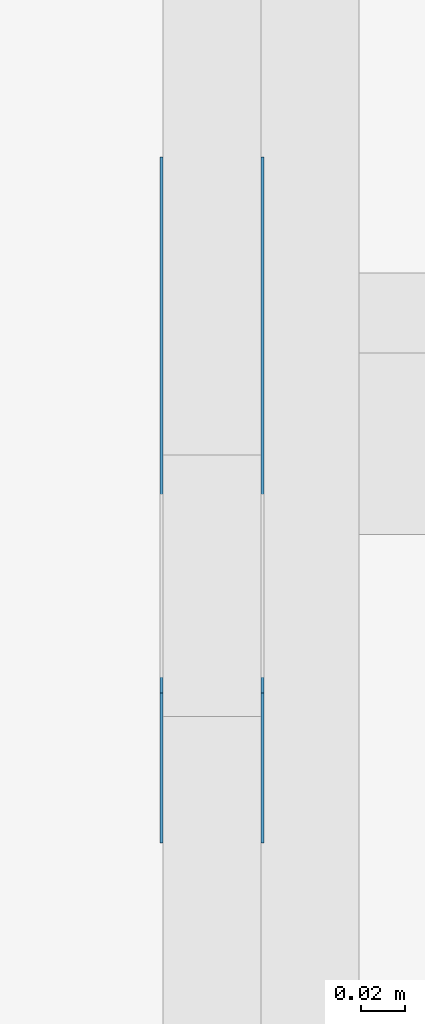
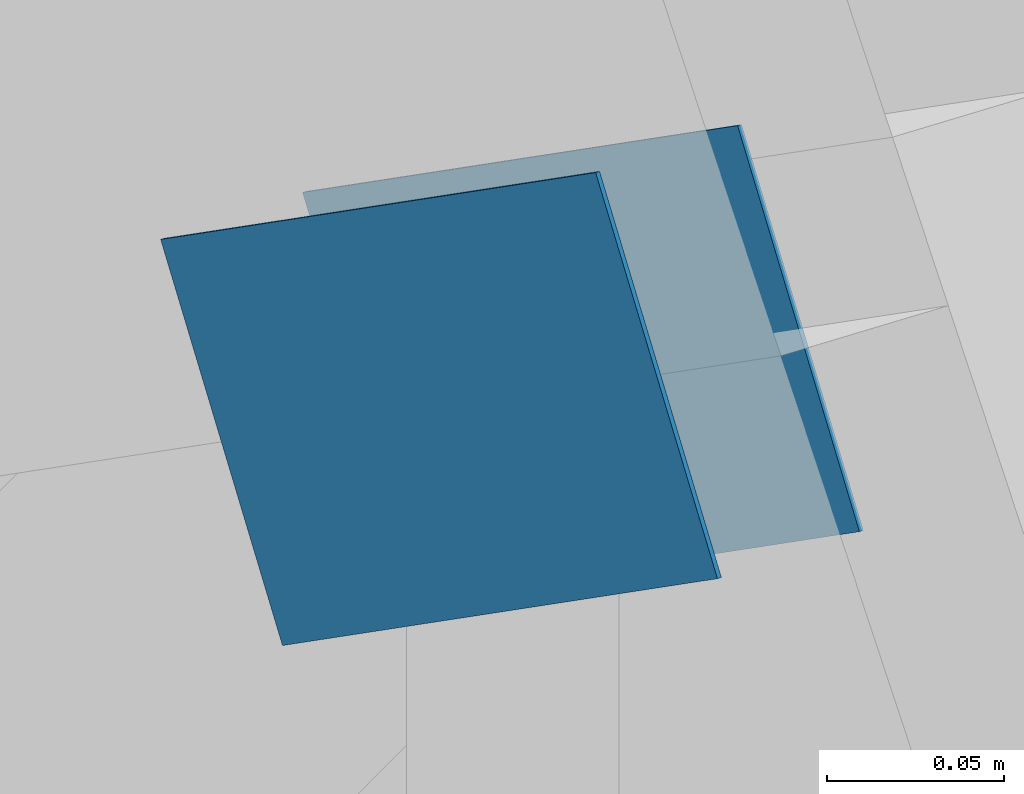
# One storey, part 59 of 70: 2 plates, 1 element without a shape of its own.
"""IFC2X3 building model written with IfcOpenShell, lengths in millimetres."""

from ifc_helpers import new_model, si_unit, frame, origin, origin_with_axes, origin_2d, place, context, project, spatial, faceted_brep, element, aggregate, save


model = new_model("IFC2X3")

# Units and contexts
model_context = context("Model", 3, precision=1e-05, world=origin())
plan_context = context("Plan", 2, precision=1e-05, world=origin_2d())
ifc_project = project(units=[si_unit("LENGTHUNIT", "METRE", prefix="MILLI"), si_unit("AREAUNIT", "SQUARE_METRE"), si_unit("VOLUMEUNIT", "CUBIC_METRE"), si_unit("SOLIDANGLEUNIT", "STERADIAN"), si_unit("PLANEANGLEUNIT", "RADIAN"), si_unit("MASSUNIT", "GRAM"), si_unit("TIMEUNIT", "SECOND"), si_unit("THERMODYNAMICTEMPERATUREUNIT", "DEGREE_CELSIUS"), si_unit("LUMINOUSINTENSITYUNIT", "LUMEN")], contexts=[model_context, plan_context])

# Site, building, storey
site_placement = place(None, origin_with_axes())
site = spatial("IfcSite", under=ifc_project, at=site_placement, CompositionType="ELEMENT")
building_placement = place(site_placement, origin_with_axes())
building = spatial("IfcBuilding", under=site, at=building_placement, Name="Layout 1", CompositionType="ELEMENT")
storey_placement = place(building_placement, origin_with_axes())
storey = spatial("IfcBuildingStorey", under=building, at=storey_placement, Name="Storey 1", CompositionType="ELEMENT", Elevation=0.0)

# Assembly, plates
assembly_placement = place(storey_placement, frame((11150.0, 8000.0, -9.081170196248781e-13), z_axis=(-1.0, 1.836909530733566e-16, 6.123031769111886e-17), x_axis=(-1.836909530733566e-16, -1.0, 0.0)))
assembly = element("IfcElementAssembly", 1, at=assembly_placement, inside=storey, Name="T3", AssemblyPlace="FACTORY", PredefinedType="TRUSS")
plate_1_placement = place(assembly_placement, frame((1312.2224814137073, 1607.5305531611004, 0.0), z_axis=(0.0, 0.0, 1.0), x_axis=(0.8191520442886487, 0.5735764363515361, 0.0)))
plate_1 = element("IfcPlate", 2, at=plate_1_placement, context=model_context, shape_type="Brep", body=[
    faceted_brep([(300.00000000000045, 120.0, 1.3), (0.0, 120.0, 1.3), (4.547473508864641e-13, 0.0, 1.3), (300.00000000000045, 0.0, 1.3), (0.0, 120.0, 0.0), (300.00000000000045, 120.0, 3.6738190614671375e-14), (300.00000000000045, 1.1368683772161603e-13, 3.6738190614671375e-14), (4.547473508864641e-13, 1.1368683772161603e-13, 5.56886495279458e-29), (300.00000000000045, -5.510728592200723e-14, 1.0335317815093051e-29), (300.00000000000045, -5.5027686509008776e-14, 1.3), (4.547473508864641e-13, 7.959941299819867e-17, 1.3), (4.547473508864641e-13, -2.558622685737995e-28, 1.566652798994412e-44), (300.00000000000045, 120.00000000000011, 0.0), (300.00000000000045, 120.00000000000011, 1.3), (300.00000000000045, 1.1368683772161603e-13, 1.3), (300.00000000000045, 1.1368683772161603e-13, 0.0), (0.0, 120.0, 0.0), (0.0, 120.0, 1.3), (300.00000000000045, 120.00000000000011, 1.3), (300.00000000000045, 120.00000000000011, 0.0), (4.547473508864641e-13, 0.0, 0.0), (4.548269502994626e-13, 2.730461286921124e-31, 1.3), (4.319658508927097e-14, 120.0, 1.3), (4.3116985676272535e-14, 120.0, -2.6400667308415888e-30)], [[[0, 1, 2, 3]], [[4, 5, 6, 7]], [[8, 9, 10, 11]], [[12, 13, 14, 15]], [[16, 17, 18, 19]], [[20, 21, 22, 23]]]),
])
plate_2_placement = place(assembly_placement, frame((1312.2224814137073, 1607.5305531611004, -46.300000000000004), z_axis=(0.0, 0.0, 1.0), x_axis=(0.8191520442886487, 0.5735764363515361, 0.0)))
plate_2 = element("IfcPlate", 3, at=plate_2_placement, context=model_context, shape_type="Brep", body=[
    faceted_brep([(300.00000000000045, 120.0, 1.2999999999999972), (0.0, 120.0, 1.2999999999999972), (4.547473508864641e-13, 0.0, 1.2999999999999972), (300.00000000000045, 0.0, 1.2999999999999972), (0.0, 120.0, 0.0), (300.00000000000045, 120.0, 3.6738190614671375e-14), (300.00000000000045, 1.1368683772161603e-13, 3.6738190614671375e-14), (4.547473508864641e-13, 1.1368683772161603e-13, 5.56886495279458e-29), (300.00000000000045, -5.510728592200723e-14, 1.0335317815093051e-29), (300.00000000000045, -5.5027686509008776e-14, 1.2999999999999972), (4.547473508864641e-13, 7.959941299819848e-17, 1.2999999999999972), (4.547473508864641e-13, -2.558622685737995e-28, 1.566652798994412e-44), (300.00000000000045, 120.00000000000011, 0.0), (300.00000000000045, 120.00000000000011, 1.2999999999999972), (300.00000000000045, 1.1368683772161603e-13, 1.2999999999999972), (300.00000000000045, 1.1368683772161603e-13, 0.0), (0.0, 120.0, 0.0), (0.0, 120.0, 1.2999999999999972), (300.00000000000045, 120.00000000000011, 1.2999999999999972), (300.00000000000045, 120.00000000000011, 0.0), (4.547473508864641e-13, 0.0, 0.0), (4.548269502994626e-13, 2.730461286921124e-31, 1.2999999999999972), (4.319658508927097e-14, 120.0, 1.2999999999999972), (4.3116985676272535e-14, 120.0, -2.6400667308415888e-30)], [[[0, 1, 2, 3]], [[4, 5, 6, 7]], [[8, 9, 10, 11]], [[12, 13, 14, 15]], [[16, 17, 18, 19]], [[20, 21, 22, 23]]]),
])
aggregate(assembly, [plate_1, plate_2])

save(model, "model.ifc")
